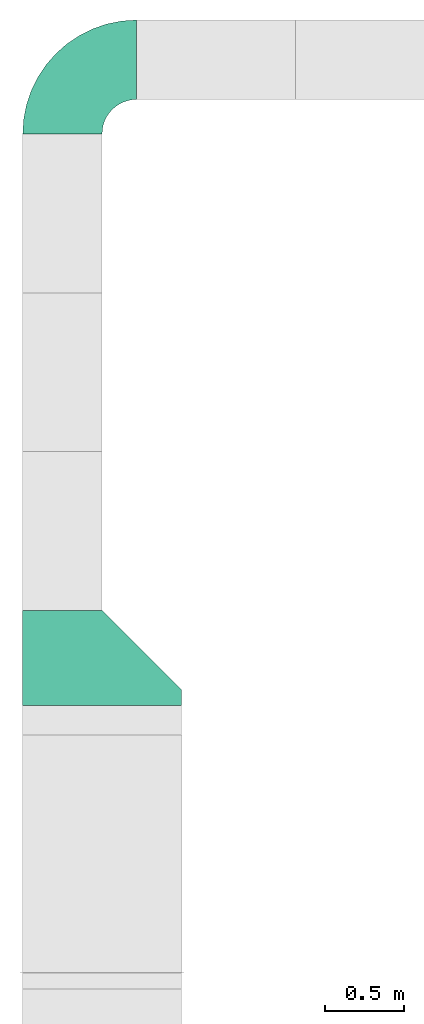
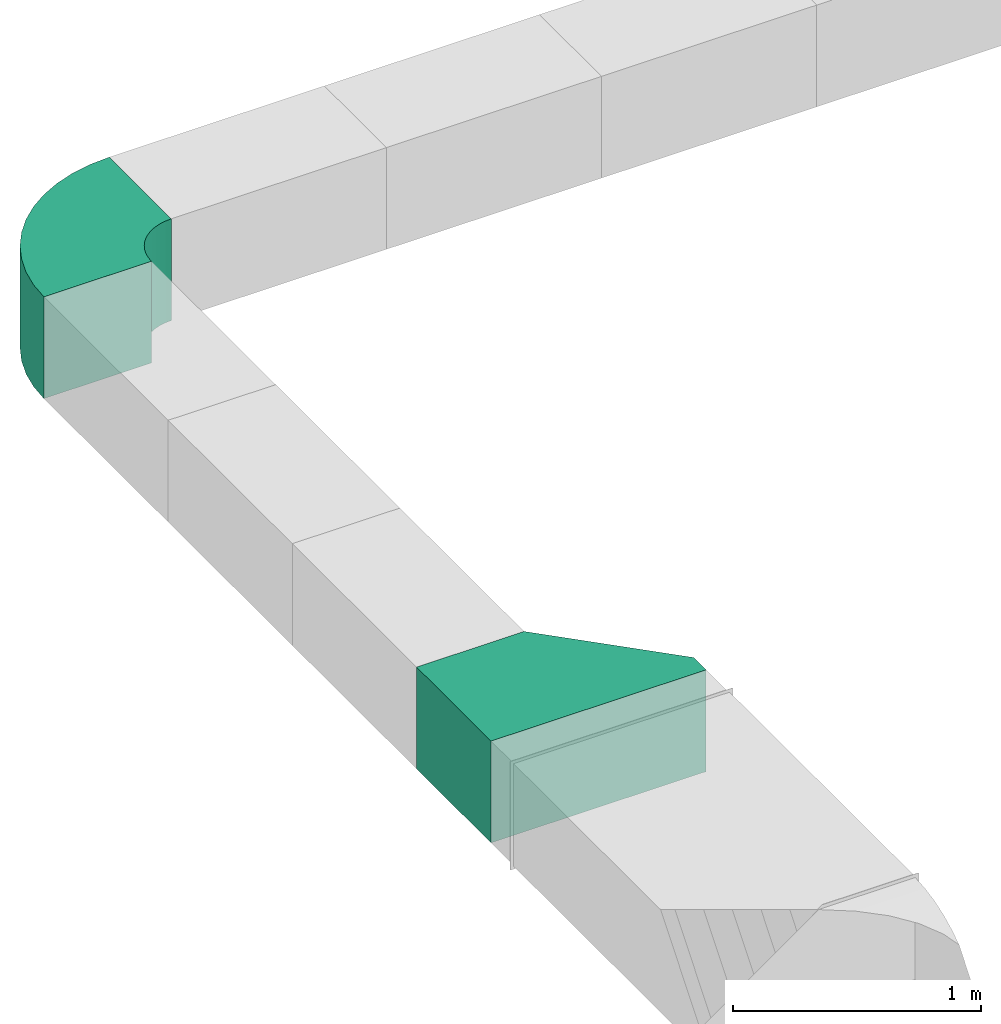
# One storey, part 3 of 3: 2 duct fittings.
"""IFC4X3_ADD2 building model written with IfcOpenShell, lengths in millimetres."""

from ifc_helpers import new_model, entity, si_unit, converted_unit, frame, origin_with_axes, origin_2d_with_axis, place, context, subcontext, project, spatial, polygons, source, transform, mapped, type_object, type_shapes, element, save


model = new_model("IFC4X3_ADD2")

# Units and contexts
model_context = context("Model", 3, precision=1e-05, world=origin_with_axes())
plan_context = context("Plan", 2, precision=1e-05, world=origin_2d_with_axis())
body_context = subcontext(model_context, "Body", "Model", "MODEL_VIEW")
ifc_project = project(units=[si_unit("VOLUMEUNIT", "CUBIC_METRE"), si_unit("LENGTHUNIT", "METRE", prefix="MILLI"), converted_unit("PLANEANGLEUNIT", "degree", entity("IfcReal", 0.0174532925199433), si_unit("PLANEANGLEUNIT", "RADIAN"), dimensions=[0, 0, 0, 0, 0, 0, 0]), si_unit("AREAUNIT", "SQUARE_METRE")], contexts=[model_context, plan_context])

# Site, building, storey
site_placement = place(None, origin_with_axes())
site = spatial("IfcSite", under=ifc_project, at=site_placement)
building_placement = place(site_placement, origin_with_axes())
building = spatial("IfcBuilding", under=site, at=building_placement, Name="Building")
storey_placement = place(building_placement, origin_with_axes())
storey = spatial("IfcBuildingStorey", under=building, at=storey_placement, Name="Storey")

# Duct fittings
duct_fitting_type_1 = type_object("IfcDuctFittingType", Name="Transition", PredefinedType="TRANSITION")
shared_shape_1 = source(origin_with_axes(), body_context, "Body", "Tessellation", [
    polygons([(500.0, -250.0, 100.000001490116), (500.0, 250.0, 100.000001490116), (499.99988079071, 250.000149011612, 600.000262260437), (-500.0, 250.0, 100.000001490116), (-8.20608363483188e-05, -249.999865889549, 600.000262260437), (-8.20608363483188e-05, 250.000149011612, 600.000262260437), (-500.0, -250.0, 100.000001490116), (-500.0, -250.0, 0.0), (500.0, -250.0, 0.0), (500.0, 250.0, 0.0), (-500.0, 250.0, 0.0), (499.99988079071, -249.999865889549, 600.000262260437)], [[[9, 1, 7, 8]], [[3, 2, 4]], [[5, 6, 4]], [[10, 11, 4, 2]], [[11, 8, 7, 4]], [[10, 9, 8, 11]], [[2, 1, 9, 10]], [[5, 12, 3, 6]], [[4, 6, 3]], [[1, 12, 5]], [[4, 7, 5]], [[5, 7, 1]], [[3, 12, 1, 2]]]),
])
type_shapes(duct_fitting_type_1, [shared_shape_1])
duct_fitting_1_placement = place(storey_placement, frame((-133.152917027473, 1890.5029296875, 4035.20965576172), z_axis=(-1.5099578831723e-07, 0.999999999999986, 7.54979012640422e-08), x_axis=(-0.999999999999985, -1.50995802528084e-07, 8.74227907843292e-08)))
element("IfcDuctFitting", 1, at=duct_fitting_1_placement, inside=storey, type_object=duct_fitting_type_1, Name="DuctFitting", context=body_context, shape_type="MappedRepresentation", body=[
    mapped(shared_shape_1, transform((0.0, 0.0, 0.0), x_axis=(1.0, 0.0, 0.0), y_axis=(0.0, 1.0, 0.0), z_axis=(0.0, 0.0, 1.0), scale=1.0)),
])
duct_fitting_type_2 = type_object("IfcDuctFittingType", Name="Duct Bend 500x500", PredefinedType="BEND")
shared_shape_2 = source(origin_with_axes(), body_context, "Body", "Tessellation", [
    polygons([(-249.999984741211, -249.999984741211, 0.0), (249.999984741211, -249.999984741211, 0.0), (-249.999984741211, 249.999984741211, 0.0), (249.999984741211, 249.999984741211, 0.0), (-251.864837646484, -250.000015258789, 28.4527187347412), (243.857559204102, -250.000015258789, 93.7158126831055), (-251.864837646484, 249.999938964844, 28.4527187347412), (243.857559204102, 249.999938964844, 93.7158126831055), (-257.427551269531, -250.000045776367, 56.4186096191406), (225.535339355469, -250.000045776367, 185.828140258789), (-257.427551269531, 249.999893188477, 56.4186096191406), (225.535339355469, 249.999893188477, 185.828140258789), (-266.592956542969, -250.000076293945, 83.4191665649414), (195.346771240234, -250.000076293945, 274.760894775391), (-266.592956542969, 249.999847412109, 83.4191665649414), (195.346771240234, 249.999847412109, 274.760894775391), (-279.204254150391, -250.000106811523, 108.992408752441), (153.808441162109, -250.000106811523, 358.992431640625), (-279.204254150391, 249.999801635742, 108.992408752441), (153.808441162109, 249.999801635742, 358.992431640625), (-295.045654296875, -250.000137329102, 132.700759887695), (101.63102722168, -250.000137329102, 437.081512451172), (-295.045654296875, 249.999755859375, 132.700759887695), (101.63102722168, 249.999755859375, 437.081512451172), (-313.846099853516, -250.00016784668, 154.138565063477), (39.7073211669922, -250.00016784668, 507.692016601562), (-313.846099853516, 249.999710083008, 154.138565063477), (39.7073211669922, 249.999710083008, 507.692016601562), (-335.283874511719, -250.000198364258, 172.939025878906), (-30.9031295776367, -250.000198364258, 569.61572265625), (-335.283874511719, 249.999664306641, 172.939025878906), (-30.9031295776367, 249.999664306641, 569.61572265625), (-358.992218017578, -250.000228881836, 188.78044128418), (-108.992164611816, -250.000228881836, 621.793151855469), (-358.992218017578, 249.999633789062, 188.78044128418), (-108.992172241211, 249.999633789062, 621.793151855469), (-384.565460205078, -250.000259399414, 201.391784667969), (-193.223678588867, -250.000259399414, 663.331604003906), (-384.565460205078, 249.999588012695, 201.391784667969), (-193.223678588867, 249.999588012695, 663.331604003906), (-411.565979003906, -250.000289916992, 210.557250976562), (-282.156433105469, -250.000289916992, 693.520202636719), (-411.565979003906, 249.999542236328, 210.557250976562), (-282.156433105469, 249.999542236328, 693.520202636719), (-439.531890869141, -250.000305175781, 216.120040893555), (-374.268737792969, -250.000305175781, 711.842468261719), (-439.531890869141, 249.999496459961, 216.120040893555), (-374.268737792969, 249.999496459961, 711.842468261719), (-467.984619140625, -250.000335693359, 217.984924316406), (-467.984588623047, -250.000335693359, 717.984985351562), (-467.984619140625, 249.999450683594, 217.984924316406), (-467.984588623047, 249.999450683594, 717.984985351562)], [[[1, 3, 4, 2]], [[8, 7, 11, 12]], [[4, 3, 7, 8]], [[1, 2, 6, 5]], [[2, 4, 8, 6]], [[3, 1, 5, 7]], [[10, 12, 16, 14]], [[5, 6, 10, 9]], [[6, 8, 12, 10]], [[7, 5, 9, 11]], [[16, 15, 19, 20]], [[11, 9, 13, 15]], [[12, 11, 15, 16]], [[9, 10, 14, 13]], [[17, 18, 22, 21]], [[13, 14, 18, 17]], [[14, 16, 20, 18]], [[15, 13, 17, 19]], [[22, 24, 28, 26]], [[18, 20, 24, 22]], [[19, 17, 21, 23]], [[20, 19, 23, 24]], [[28, 27, 31, 32]], [[23, 21, 25, 27]], [[24, 23, 27, 28]], [[21, 22, 26, 25]], [[30, 32, 36, 34]], [[25, 26, 30, 29]], [[26, 28, 32, 30]], [[27, 25, 29, 31]], [[34, 36, 40, 38]], [[31, 29, 33, 35]], [[32, 31, 35, 36]], [[29, 30, 34, 33]], [[40, 39, 43, 44]], [[35, 33, 37, 39]], [[36, 35, 39, 40]], [[33, 34, 38, 37]], [[42, 44, 48, 46]], [[37, 38, 42, 41]], [[38, 40, 44, 42]], [[39, 37, 41, 43]], [[47, 45, 49, 51]], [[43, 41, 45, 47]], [[44, 43, 47, 48]], [[41, 42, 46, 45]], [[49, 50, 52, 51]], [[48, 47, 51, 52]], [[45, 46, 50, 49]], [[46, 48, 52, 50]]]),
])
type_shapes(duct_fitting_type_2, [shared_shape_2])
duct_fitting_2_placement = place(storey_placement, frame((84.8316848278046, 5958.48798751831, 4035.20965576172), z_axis=(-0.999999999999959, -2.82129974493716e-07, -4.37113882867362e-08), x_axis=(-2.82129974493717e-07, 0.99999999999996, 0.0)))
element("IfcDuctFitting", 2, at=duct_fitting_2_placement, inside=storey, type_object=duct_fitting_type_2, Name="DuctFitting", context=body_context, shape_type="MappedRepresentation", body=[
    mapped(shared_shape_2, transform((0.0, 0.0, 0.0), x_axis=(1.0, 0.0, 0.0), y_axis=(0.0, 1.0, 0.0), z_axis=(0.0, 0.0, 1.0), scale=1.0)),
])

save(model, "model.ifc")
